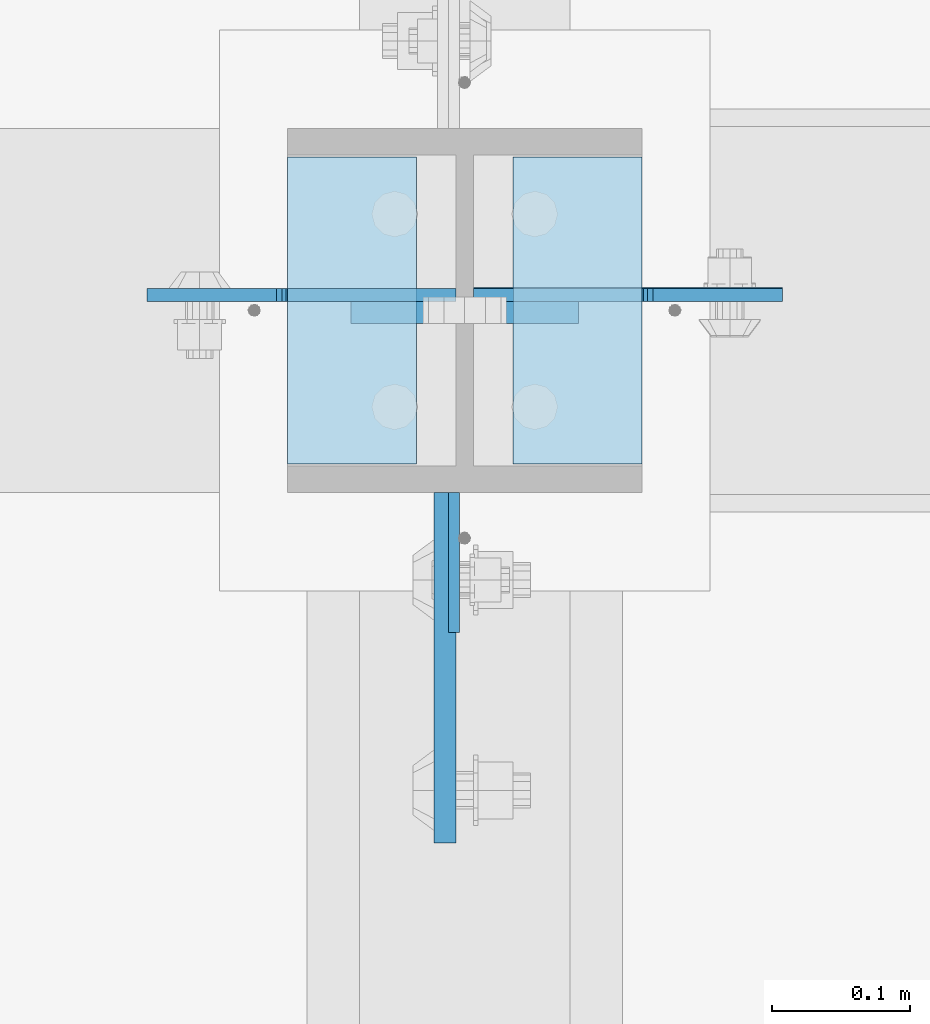
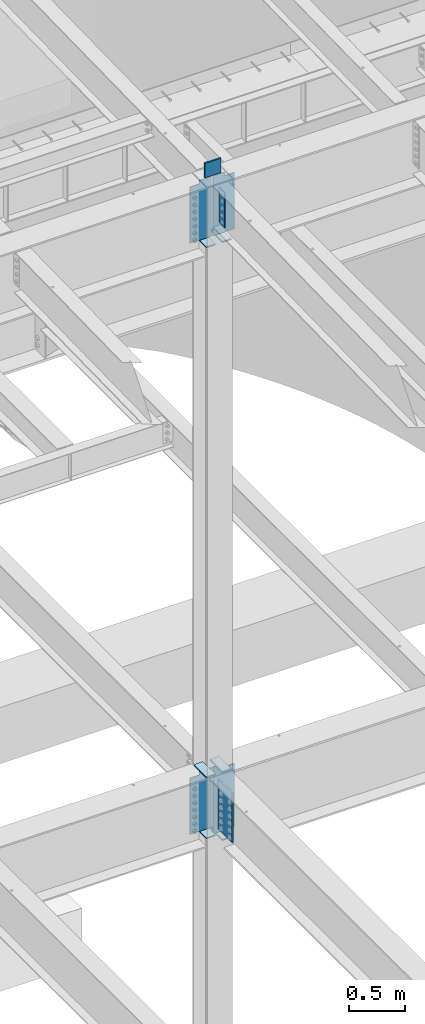
# One storey, part 1554 of 1763: 13 plates, 1 element without a shape of its own.
"""IFC2X3 building model written with IfcOpenShell, lengths in millimetres."""

from ifc_helpers import new_model, si_unit, frame, origin_with_axes, place, context, subcontext, project, spatial, faceted_brep, material, type_object, element, aggregate, save


model = new_model("IFC2X3")

# Units and contexts
model_context = context("Model", 3, precision=1e-05, world=origin_with_axes())
body_context = subcontext(model_context, "Body", "Model", "MODEL_VIEW")
ifc_project = project(units=[si_unit("LENGTHUNIT", "METRE", prefix="MILLI"), si_unit("AREAUNIT", "SQUARE_METRE"), si_unit("VOLUMEUNIT", "CUBIC_METRE"), si_unit("MASSUNIT", "GRAM", prefix="KILO"), si_unit("TIMEUNIT", "SECOND"), si_unit("PLANEANGLEUNIT", "RADIAN"), si_unit("SOLIDANGLEUNIT", "STERADIAN"), si_unit("THERMODYNAMICTEMPERATUREUNIT", "DEGREE_CELSIUS"), si_unit("LUMINOUSINTENSITYUNIT", "LUMEN")], contexts=[model_context])

# Site, building, storey
site_placement = place(None, origin_with_axes())
site = spatial("IfcSite", under=ifc_project, at=site_placement, CompositionType="ELEMENT")
building_placement = place(site_placement, origin_with_axes())
building = spatial("IfcBuilding", under=site, at=building_placement, Name="Undefined", CompositionType="ELEMENT")
storey_placement = place(building_placement, origin_with_axes())
storey = spatial("IfcBuildingStorey", under=building, at=storey_placement, Name="Undefined", CompositionType="ELEMENT", Elevation=0.0)

# Assembly, plates
assembly_placement = place(storey_placement, origin_with_axes())
assembly = element("IfcElementAssembly", 1, at=assembly_placement, inside=storey, Name="COLUMN", AssemblyPlace="NOTDEFINED", PredefinedType="RIGID_FRAME")
ifc_material_1 = material(Name="STEEL/A36")
plate_type_1 = type_object("IfcPlateType", PredefinedType="NOTDEFINED")
plate_1_placement = place(assembly_placement, frame((-49410.3750236983, 44673.8374999996, 11553.9948078388), z_axis=(0.0, -1.0, 0.0), x_axis=(0.0, 0.0, -1.0)))
plate_1 = element("IfcPlate", 2, at=plate_1_placement, type_object=plate_type_1, material=ifc_material_1, Name="PLATE", context=body_context, shape_type="Brep", body=[
    faceted_brep([(0.0, -3.96900000000096, 0.0), (-1.18234311230481e-11, -3.96900000000096, 101.599998474121), (-1.18234311230481e-11, 3.96900000000096, 101.599998474121), (0.0, 3.96900000000096, 0.0), (381.0, -3.96899999999732, 101.599998474121), (381.0, 3.96899999999732, 101.599998474121), (381.0, -3.96900000001915, 3.34694050252438e-10), (381.0, 3.9690000000046, 3.20142135024071e-10)], [[[0, 1, 2, 3]], [[1, 4, 5, 2]], [[4, 6, 7, 5]], [[6, 0, 3, 7]], [[5, 7, 3, 2]], [[6, 4, 1, 0]]]),
])
ifc_material_2 = material(Name="STEEL/A572-50")
plate_type_2 = type_object("IfcPlateType", PredefinedType="NOTDEFINED")
plate_2_placement = place(assembly_placement, frame((-49319.8872721725, 44805.5999999732, 11760.2588348652), z_axis=(0.0, 0.0, -1.0), x_axis=(-1.0, 0.0, 0.0)))
plate_2 = element("IfcPlate", 3, at=plate_2_placement, type_object=plate_type_2, material=ifc_material_2, Name="PLATE", context=body_context, shape_type="Brep", body=[
    faceted_brep([(7.27595761418343e-12, 9.52500000000146, 155.574990844727), (-1.45519152283669e-11, 7.27595761418343e-12, 165.099990844727), (165.099990844727, 0.0, 165.099990844727), (165.099990844727, 9.52500000000146, 155.574990844727), (-3.63797880709171e-11, -9.5249999999869, 155.574990844727), (165.099990844727, -9.52500000000146, 155.574990844727), (0.0, 9.52500000000146, 0.0), (0.0, -9.52500000000146, 0.0), (165.099990844727, -9.52500000000146, 0.0), (165.099990844727, 9.52500000000146, 0.0)], [[[0, 1, 2, 3]], [[1, 4, 5, 2]], [[6, 7, 4, 1, 0]], [[5, 8, 9, 3, 2]], [[8, 7, 6, 9]], [[9, 6, 0, 3]], [[7, 8, 5, 4]]]),
])
plate_type_3 = type_object("IfcPlateType", PredefinedType="NOTDEFINED")
plate_3_placement = place(assembly_placement, frame((-49273.8497736983, 44694.475, 10928.4088287617), z_axis=(0.0, 1.0, 0.0), x_axis=(-1.0, 0.0, 0.0)))
plate_3 = element("IfcPlate", 4, at=plate_3_placement, type_object=plate_type_3, material=ifc_material_1, Name="PLATE", context=body_context, shape_type="Brep", body=[
    faceted_brep([(0.0, -6.34999999999491, 1.45519152283669e-11), (0.0, -6.35000000000036, 222.25), (0.0, 6.35000000000036, 222.25), (0.0, 6.34999999999491, -2.91038304567337e-11), (93.6624984741211, -6.35000000000036, 222.25), (93.6624984741211, 6.35000000000036, 222.25), (93.6624984741211, -6.35000000000036, 0.0), (93.6624984741211, 6.35000000000036, 0.0)], [[[0, 1, 2, 3]], [[1, 4, 5, 2]], [[4, 6, 7, 5]], [[6, 0, 3, 7]], [[5, 7, 3, 2]], [[6, 4, 1, 0]]]),
])
plate_4_placement = place(assembly_placement, frame((-49531.0247736984, 44916.725, 10928.4088287617), z_axis=(0.0, -1.0, 0.0), x_axis=(1.0, 0.0, 0.0)))
plate_4 = element("IfcPlate", 5, at=plate_4_placement, type_object=plate_type_3, material=ifc_material_1, Name="PLATE", context=body_context, shape_type="Brep", body=[
    faceted_brep([(0.0, -6.34999999999491, 1.45519152283669e-11), (0.0, -6.35000000000036, 222.25), (0.0, 6.35000000000036, 222.25), (0.0, 6.34999999999491, -2.91038304567337e-11), (93.6624984741211, -6.35000000000036, 222.25), (93.6624984741211, 6.35000000000036, 222.25), (93.6624984741211, -6.35000000000036, 0.0), (93.6624984741211, 6.35000000000036, 0.0)], [[[0, 1, 2, 3]], [[1, 4, 5, 2]], [[4, 6, 7, 5]], [[6, 0, 3, 7]], [[5, 7, 3, 2]], [[6, 4, 1, 0]]]),
])
plate_5_placement = place(assembly_placement, frame((-49531.0247736984, 44916.725, 4527.54998779297), z_axis=(0.0, -1.0, 0.0), x_axis=(1.0, 0.0, 0.0)))
plate_5 = element("IfcPlate", 6, at=plate_5_placement, type_object=plate_type_3, material=ifc_material_1, Name="PLATE", context=body_context, shape_type="Brep", body=[
    faceted_brep([(0.0, -6.34999999999491, 1.45519152283669e-11), (0.0, -6.35000000000036, 222.25), (0.0, 6.35000000000036, 222.25), (0.0, 6.34999999999491, -2.91038304567337e-11), (93.6624984741211, -6.35000000000036, 222.25), (93.6624984741211, 6.35000000000036, 222.25), (93.6624984741211, -6.35000000000036, 0.0), (93.6624984741211, 6.35000000000036, 0.0)], [[[0, 1, 2, 3]], [[1, 4, 5, 2]], [[4, 6, 7, 5]], [[6, 0, 3, 7]], [[5, 7, 3, 2]], [[6, 4, 1, 0]]]),
])
plate_6_placement = place(assembly_placement, frame((-49531.0247736984, 44916.725, 5187.95), z_axis=(0.0, -1.0, 0.0), x_axis=(1.0, 0.0, 0.0)))
plate_6 = element("IfcPlate", 7, at=plate_6_placement, type_object=plate_type_3, material=ifc_material_1, Name="PLATE", context=body_context, shape_type="Brep", body=[
    faceted_brep([(0.0, -6.34999999999491, 1.45519152283669e-11), (0.0, -6.35000000000036, 222.25), (0.0, 6.35000000000036, 222.25), (0.0, 6.34999999999491, -2.91038304567337e-11), (93.6624984741211, -6.35000000000036, 222.25), (93.6624984741211, 6.35000000000036, 222.25), (93.6624984741211, -6.35000000000036, 0.0), (93.6624984741211, 6.35000000000036, 0.0)], [[[0, 1, 2, 3]], [[1, 4, 5, 2]], [[4, 6, 7, 5]], [[6, 0, 3, 7]], [[5, 7, 3, 2]], [[6, 4, 1, 0]]]),
])
plate_7_placement = place(assembly_placement, frame((-49273.8497736983, 44694.475, 4451.34997558594), z_axis=(0.0, 1.0, 0.0), x_axis=(-1.0, 0.0, 0.0)))
plate_7 = element("IfcPlate", 8, at=plate_7_placement, type_object=plate_type_3, material=ifc_material_1, Name="PLATE", context=body_context, shape_type="Brep", body=[
    faceted_brep([(0.0, -6.34999999999491, 1.45519152283669e-11), (0.0, -6.35000000000036, 222.25), (0.0, 6.35000000000036, 222.25), (0.0, 6.34999999999491, -2.91038304567337e-11), (93.6624984741211, -6.35000000000036, 222.25), (93.6624984741211, 6.35000000000036, 222.25), (93.6624984741211, -6.35000000000036, 0.0), (93.6624984741211, 6.35000000000036, 0.0)], [[[0, 1, 2, 3]], [[1, 4, 5, 2]], [[4, 6, 7, 5]], [[6, 0, 3, 7]], [[5, 7, 3, 2]], [[6, 4, 1, 0]]]),
])
plate_8_placement = place(assembly_placement, frame((-49273.8497736983, 44694.475, 5187.95), z_axis=(0.0, 1.0, 0.0), x_axis=(-1.0, 0.0, 0.0)))
plate_8 = element("IfcPlate", 9, at=plate_8_placement, type_object=plate_type_3, material=ifc_material_1, Name="PLATE", context=body_context, shape_type="Brep", body=[
    faceted_brep([(0.0, -6.34999999999491, 1.45519152283669e-11), (0.0, -6.35000000000036, 222.25), (0.0, 6.35000000000036, 222.25), (0.0, 6.34999999999491, -2.91038304567337e-11), (93.6624984741211, -6.35000000000036, 222.25), (93.6624984741211, 6.35000000000036, 222.25), (93.6624984741211, -6.35000000000036, 0.0), (93.6624984741211, 6.35000000000036, 0.0)], [[[0, 1, 2, 3]], [[1, 4, 5, 2]], [[4, 6, 7, 5]], [[6, 0, 3, 7]], [[5, 7, 3, 2]], [[6, 4, 1, 0]]]),
])
plate_type_4 = type_object("IfcPlateType", PredefinedType="NOTDEFINED")
plate_9_placement = place(assembly_placement, frame((-49416.7247736983, 44673.8375, 5143.5), z_axis=(0.0, -1.0, 0.0), x_axis=(0.0, 0.0, -1.0)))
plate_9 = element("IfcPlate", 10, at=plate_9_placement, type_object=plate_type_4, material=ifc_material_2, Name="PLATE", context=body_context, shape_type="Brep", body=[
    faceted_brep([(-7.27595761418343e-12, -7.9375, 0.0), (0.0, -7.9375, 254.0), (0.0, 7.9375, 254.0), (-7.27595761418343e-12, 7.9375, 0.0), (533.400024414062, -7.9375, 254.0), (533.400024414062, 7.9375, 254.0), (533.400024414062, -7.9375, 0.0), (533.400024414062, 7.9375, 0.0)], [[[0, 1, 2, 3]], [[1, 4, 5, 2]], [[4, 6, 7, 5]], [[6, 0, 3, 7]], [[5, 7, 3, 2]], [[6, 4, 1, 0]]]),
])
plate_type_5 = type_object("IfcPlateType", PredefinedType="NOTDEFINED")
plate_10_placement = place(assembly_placement, frame((-49396.0872736984, 44816.7124999732, 11582.4588409687), z_axis=(1.0, 0.0, 0.0), x_axis=(0.0, 0.0, -1.0)))
plate_10 = element("IfcPlate", 11, at=plate_10_placement, type_object=plate_type_5, material=ifc_material_1, Name="PLATE", context=body_context, shape_type="Brep", body=[
    faceted_brep([(25.4000001907334, -4.76250000000073, 122.237503051758), (25.4000001907334, 4.76250000000073, 122.237503051758), (-2.5465851649642e-11, 4.76250000019581, 122.237500000236), (-3.45607986673713e-11, -4.76249999983202, 122.23750000025), (30.2600797087798, -4.76250000000073, 123.204232974349), (30.2600797087798, 4.76250000000073, 123.204232974349), (34.3802561769335, -4.76250000000073, 125.957246874823), (34.3802561769335, 4.76250000000073, 125.957246874823), (37.133270077411, -4.76250000000073, 130.077423342977), (37.133270077411, 4.76250000000073, 130.077423342977), (38.0999999999985, -4.76250000000073, 134.937502861023), (38.0999999999985, 4.76250000000073, 134.937502861023), (38.0999999999985, -4.76250000000073, 223.837493896484), (38.0999999999985, 4.76250000000073, 223.837493896484), (647.700012207031, -4.76250000000073, 0.0), (0.0, -4.76249999999982, 0.0), (0.0, 4.76249999999982, 0.0), (647.700012207031, 4.76250000000073, 0.0), (647.700012207031, -4.76250000000073, 223.837493896484), (647.700012207031, 4.76250000000073, 223.837493896484)], [[[0, 1, 2, 3]], [[4, 5, 1, 0]], [[6, 7, 5, 4]], [[8, 9, 7, 6]], [[10, 11, 9, 8]], [[12, 13, 11, 10]], [[14, 15, 16, 17]], [[18, 14, 17, 19]], [[8, 6, 4, 0, 3, 15, 14, 18, 12, 10]], [[16, 15, 3, 2]], [[19, 17, 16, 2, 1, 5, 7, 9, 11, 13]], [[18, 19, 13, 12]]]),
])
plate_11_placement = place(assembly_placement, frame((-49408.7872736983, 44816.7124999732, 11582.4588409687), z_axis=(-1.0, 0.0, 0.0), x_axis=(0.0, 0.0, -1.0)))
plate_11 = element("IfcPlate", 12, at=plate_11_placement, type_object=plate_type_5, material=ifc_material_1, Name="PLATE", context=body_context, shape_type="Brep", body=[
    faceted_brep([(25.4000001907334, -4.76250000000073, 122.237503051758), (25.4000001907334, 4.76250000000073, 122.237503051758), (-2.5465851649642e-11, 4.76250000019581, 122.237500000236), (-3.45607986673713e-11, -4.76249999983202, 122.23750000025), (30.2600797087798, -4.76250000000073, 123.204232974349), (30.2600797087798, 4.76250000000073, 123.204232974349), (34.3802561769335, -4.76250000000073, 125.957246874823), (34.3802561769335, 4.76250000000073, 125.957246874823), (37.133270077411, -4.76250000000073, 130.077423342977), (37.133270077411, 4.76250000000073, 130.077423342977), (38.0999999999985, -4.76250000000073, 134.937502861023), (38.0999999999985, 4.76250000000073, 134.937502861023), (38.0999999999985, -4.76250000000073, 223.837493896484), (38.0999999999985, 4.76250000000073, 223.837493896484), (647.700012207031, -4.76250000000073, 0.0), (0.0, -4.76249999999982, 0.0), (0.0, 4.76249999999982, 0.0), (647.700012207031, 4.76250000000073, 0.0), (647.700012207031, -4.76250000000073, 223.837493896484), (647.700012207031, 4.76250000000073, 223.837493896484)], [[[0, 1, 2, 3]], [[4, 5, 1, 0]], [[6, 7, 5, 4]], [[8, 9, 7, 6]], [[10, 11, 9, 8]], [[12, 13, 11, 10]], [[14, 15, 16, 17]], [[18, 14, 17, 19]], [[8, 6, 4, 0, 3, 15, 14, 18, 12, 10]], [[16, 15, 3, 2]], [[19, 17, 16, 2, 1, 5, 7, 9, 11, 13]], [[18, 19, 13, 12]]]),
])
plate_12_placement = place(assembly_placement, frame((-49408.7872736983, 44816.7125, 5181.6), z_axis=(-1.0, 0.0, 0.0), x_axis=(0.0, 0.0, -1.0)))
plate_12 = element("IfcPlate", 13, at=plate_12_placement, type_object=plate_type_5, material=ifc_material_1, Name="PLATE", context=body_context, shape_type="Brep", body=[
    faceted_brep([(25.4000001907334, -4.76250000000073, 122.237503051758), (25.4000001907334, 4.76250000000073, 122.237503051758), (-2.5465851649642e-11, 4.76250000019581, 122.237500000236), (-3.45607986673713e-11, -4.76249999983202, 122.23750000025), (30.2600797087798, -4.76250000000073, 123.204232974349), (30.2600797087798, 4.76250000000073, 123.204232974349), (34.3802561769335, -4.76250000000073, 125.957246874823), (34.3802561769335, 4.76250000000073, 125.957246874823), (37.133270077411, -4.76250000000073, 130.077423342977), (37.133270077411, 4.76250000000073, 130.077423342977), (38.0999999999985, -4.76250000000073, 134.937502861023), (38.0999999999985, 4.76250000000073, 134.937502861023), (38.0999999999985, -4.76250000000073, 223.837493896484), (38.0999999999985, 4.76250000000073, 223.837493896484), (647.700012207031, -4.76250000000073, 0.0), (0.0, -4.76249999999982, 0.0), (0.0, 4.76249999999982, 0.0), (647.700012207031, 4.76250000000073, 0.0), (647.700012207031, -4.76250000000073, 223.837493896484), (647.700012207031, 4.76250000000073, 223.837493896484)], [[[0, 1, 2, 3]], [[4, 5, 1, 0]], [[6, 7, 5, 4]], [[8, 9, 7, 6]], [[10, 11, 9, 8]], [[12, 13, 11, 10]], [[14, 15, 16, 17]], [[18, 14, 17, 19]], [[8, 6, 4, 0, 3, 15, 14, 18, 12, 10]], [[16, 15, 3, 2]], [[19, 17, 16, 2, 1, 5, 7, 9, 11, 13]], [[18, 19, 13, 12]]]),
])
plate_13_placement = place(assembly_placement, frame((-49396.0872736984, 44817.50625, 5181.6), z_axis=(1.0, 0.0, 0.0), x_axis=(0.0, 0.0, -1.0)))
plate_13 = element("IfcPlate", 14, at=plate_13_placement, type_object=plate_type_5, material=ifc_material_1, Name="PLATE", context=body_context, shape_type="Brep", body=[
    faceted_brep([(25.4000001907334, -4.76250000000073, 122.237503051758), (25.4000001907334, 4.76250000000073, 122.237503051758), (-2.5465851649642e-11, 4.76250000019581, 122.237500000236), (-3.45607986673713e-11, -4.76249999983202, 122.23750000025), (30.2600797087798, -4.76250000000073, 123.204232974349), (30.2600797087798, 4.76250000000073, 123.204232974349), (34.3802561769335, -4.76250000000073, 125.957246874823), (34.3802561769335, 4.76250000000073, 125.957246874823), (37.133270077411, -4.76250000000073, 130.077423342977), (37.133270077411, 4.76250000000073, 130.077423342977), (38.0999999999985, -4.76250000000073, 134.937502861023), (38.0999999999985, 4.76250000000073, 134.937502861023), (38.0999999999985, -4.76250000000073, 223.837493896484), (38.0999999999985, 4.76250000000073, 223.837493896484), (723.900024414062, -4.76250000000073, 0.0), (0.0, -4.76249999999982, 0.0), (0.0, 4.76249999999982, 0.0), (723.900024414062, 4.76250000000073, 0.0), (723.900024414062, -4.76250000000073, 223.837493896484), (723.900024414062, 4.76250000000073, 223.837493896484)], [[[0, 1, 2, 3]], [[4, 5, 1, 0]], [[6, 7, 5, 4]], [[8, 9, 7, 6]], [[10, 11, 9, 8]], [[12, 13, 11, 10]], [[14, 15, 16, 17]], [[18, 14, 17, 19]], [[8, 6, 4, 0, 3, 15, 14, 18, 12, 10]], [[16, 15, 3, 2]], [[19, 17, 16, 2, 1, 5, 7, 9, 11, 13]], [[18, 19, 13, 12]]]),
])
aggregate(assembly, [plate_2, plate_3, plate_10, plate_4, plate_11, plate_1, plate_5, plate_6, plate_12, plate_7, plate_8, plate_13, plate_9])

save(model, "model.ifc")
